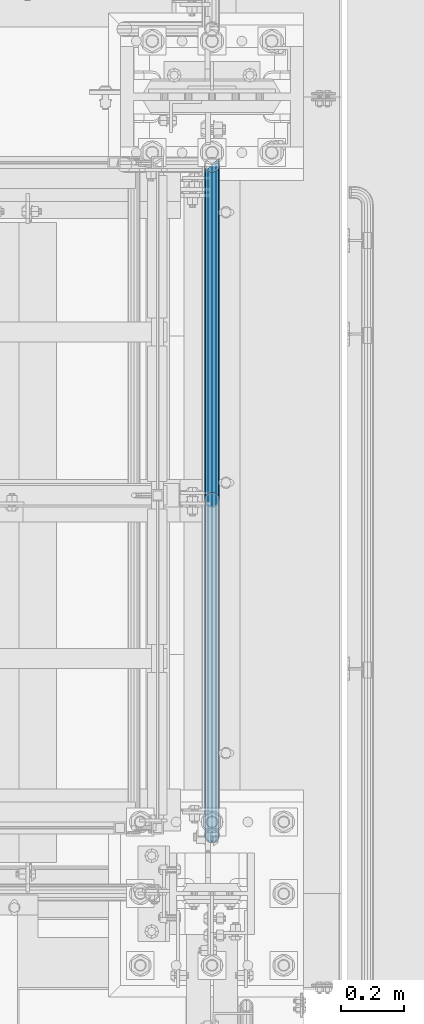
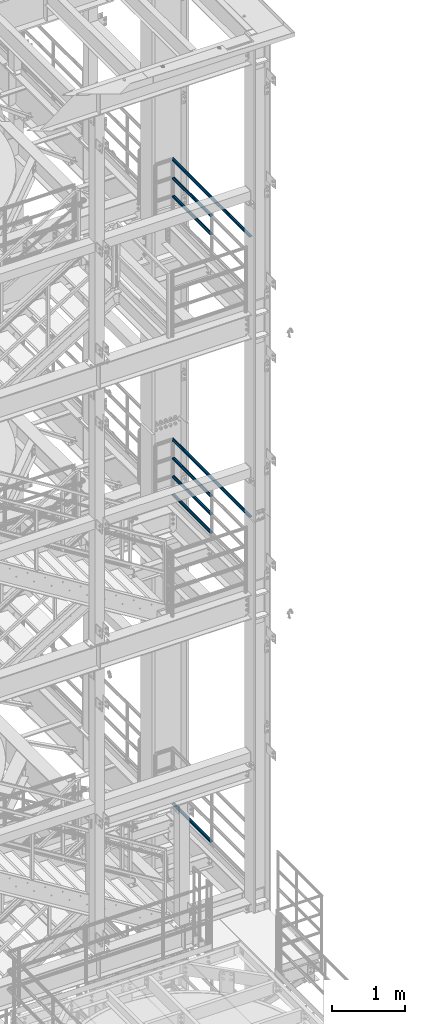
# One storey, part 1001 of 1876: 8 beams, 3 elements without a shape of their own.
"""IFC2X3 building model written with IfcOpenShell, lengths in millimetres."""

from ifc_helpers import new_model, si_unit, frame, origin_with_axes, place, context, subcontext, project, spatial, faceted_brep, material, type_object, element, aggregate, save


model = new_model("IFC2X3")

# Units and contexts
model_context = context("Model", 3, precision=1e-05, world=origin_with_axes())
body_context = subcontext(model_context, "Body", "Model", "MODEL_VIEW")
ifc_project = project(units=[si_unit("LENGTHUNIT", "METRE", prefix="MILLI"), si_unit("AREAUNIT", "SQUARE_METRE"), si_unit("VOLUMEUNIT", "CUBIC_METRE"), si_unit("MASSUNIT", "GRAM", prefix="KILO"), si_unit("TIMEUNIT", "SECOND"), si_unit("PLANEANGLEUNIT", "RADIAN"), si_unit("SOLIDANGLEUNIT", "STERADIAN"), si_unit("THERMODYNAMICTEMPERATUREUNIT", "DEGREE_CELSIUS"), si_unit("LUMINOUSINTENSITYUNIT", "LUMEN")], contexts=[model_context])

# Site, building, storey
site_placement = place(None, origin_with_axes())
site = spatial("IfcSite", under=ifc_project, at=site_placement, CompositionType="ELEMENT")
building_placement = place(site_placement, origin_with_axes())
building = spatial("IfcBuilding", under=site, at=building_placement, Name="Undefined", CompositionType="ELEMENT")
storey_placement = place(building_placement, origin_with_axes())
storey = spatial("IfcBuildingStorey", under=building, at=storey_placement, Name="Undefined", CompositionType="ELEMENT", Elevation=0.0)

# Assembly, beams
assembly_1_placement = place(storey_placement, origin_with_axes())
assembly_1 = element("IfcElementAssembly", 1, at=assembly_1_placement, inside=storey, Name="RAIL", AssemblyPlace="NOTDEFINED", PredefinedType="RIGID_FRAME")
ifc_material = material()
beam_type = type_object("IfcBeamType", Name="PIPE1-1/2SCH40", PredefinedType="NOTDEFINED")
beam_1_placement = place(assembly_1_placement, frame((7620.00000000001, -5857.08125, 18449.925), z_axis=(0.0, 0.0, -1.0), x_axis=(0.0, 1.0, 0.0)))
beam_1 = element("IfcBeam", 2, at=beam_1_placement, type_object=beam_type, material=ifc_material, Name="RAIL", ObjectType="PIPE1-1/2SCH40", context=body_context, shape_type="Brep", body=[
    faceted_brep([(0.0, 24.1299999999992, 0.0), (12.0650000000064, 20.8971929933177, -12.0649999999987), (12.0650000000064, 20.8971929933177, 12.0649999999987), (12.0650000000064, -20.8971929933177, 12.0649999999987), (12.0650000000064, -20.8971929933177, -12.0649999999987), (0.0, -24.1299999999992, 0.0), (20.8971929933249, -12.0650000000005, 20.8971929933177), (20.8971929933249, -12.0650000000005, 15.8661214311796), (15.2545715621445, -17.7076214311801, 10.2235000000001), (12.5151929933249, -20.4470000000001, 0.0), (15.2545715621445, -17.7076214311801, -10.2235000000001), (20.8971929933249, -12.0650000000005, -15.8661214311796), (20.8971929933249, -12.0650000000005, -20.8971929933177), (24.1300000000063, 0.0, -20.4470000000001), (24.1300000000063, 0.0, -24.130000000001), (21.3906214311868, -10.2235000000001, -17.7076214311819), (21.3906214311868, 10.2235000000001, -17.7076214311819), (20.8971929933249, 12.0650000000005, -15.8661214311796), (20.8971929933249, 12.0650000000005, -20.8971929933177), (15.2545715621445, 17.7076214311801, -10.2235000000001), (12.5151929933249, 20.4470000000001, 0.0), (15.2545715621445, 17.7076214311801, 10.2235000000001), (20.8971929933249, 12.0650000000005, 15.8661214311796), (20.8971929933249, 12.0650000000005, 20.8971929933177), (21.3906214311868, 10.2235000000001, 17.7076214311819), (24.1300000000064, 0.0, 20.4470000000001), (24.1300000000064, 0.0, 24.130000000001), (21.3906214311868, -10.2235000000001, 17.7076214311819), (1068.86375, 24.1300000000001, 0.0), (1056.79875, 20.8971929933186, -12.0649999999987), (1047.96655700668, 12.0649999999996, -20.8971929933177), (1068.86375, -24.1299999999792, 0.0), (1056.79875, -20.8971929933186, -12.0649999999987), (1056.79875, -20.8971929933186, 12.0649999999987), (1047.96655700668, -12.0649999999996, 20.8971929933177), (1047.96655700668, -12.0649999999996, -20.8971929933177), (1044.73375, 0.0, -24.130000000001), (1047.47312856881, 10.2235000000001, -17.7076214311819), (1044.73375, 0.0, -20.4470000000001), (1047.96655700668, 12.0650000000205, -15.8661214311578), (1047.96655700668, -12.0649999999787, -15.8661214312015), (1047.47312856882, -10.2235000000001, -17.7076214311819), (1053.60917843788, -17.7076214311801, -10.2235000000001), (1056.3485570067, -20.4470000000001, 0.0), (1053.60917843788, -17.7076214311801, 10.2235000000001), (1047.96655700668, -12.0649999999787, 15.8661214312015), (1047.47312856882, -10.2235000000001, 17.7076214311819), (1044.73375, 9.09494701772928e-13, 20.4470000000001), (1044.73375, 9.09494701772928e-13, 24.130000000001), (1047.96655700668, 12.0649999999996, 20.8971929933177), (1056.79875, 20.8971929933186, 12.0649999999987), (1047.96655700668, 12.0650000000205, 15.8661214311578), (1053.60917843784, 17.7076214311801, 10.2235000000001), (1056.34855700666, 20.4470000000001, 0.0), (1053.60917843784, 17.7076214311801, -10.2235000000001), (1047.47312856881, 10.2235000000001, 17.7076214311819)], [[[0, 1, 2]], [[3, 4, 5]], [[6, 7, 8, 9, 10, 11, 12, 4, 3]], [[13, 14, 12, 11, 15]], [[16, 17, 18, 14, 13]], [[2, 1, 18, 17, 19, 20, 21, 22, 23]], [[23, 22, 24, 25, 26]], [[26, 25, 27, 7, 6]], [[1, 0, 28, 29]], [[18, 1, 29, 30]], [[31, 32, 33]], [[6, 3, 33, 34]], [[3, 5, 31, 33]], [[5, 4, 32, 31]], [[4, 12, 35, 32]], [[12, 14, 36, 35]], [[14, 18, 30, 36]], [[37, 38, 36, 30, 39]], [[40, 35, 36, 38, 41]], [[33, 32, 35, 40, 42, 43, 44, 45, 34]], [[34, 45, 46, 47, 48]], [[26, 6, 34, 48]], [[2, 23, 49, 50]], [[23, 26, 48, 49]], [[0, 2, 50, 28]], [[28, 50, 29]], [[49, 51, 52, 53, 54, 39, 30, 29, 50]], [[48, 47, 55, 51, 49]], [[25, 24, 55, 47]], [[55, 24, 22, 21, 52, 51]], [[21, 20, 53, 52]], [[20, 19, 54, 53]], [[19, 17, 16, 37, 39, 54]], [[16, 13, 38, 37]], [[13, 15, 41, 38]], [[41, 15, 11, 10, 42, 40]], [[10, 9, 43, 42]], [[9, 8, 44, 43]], [[8, 7, 27, 46, 45, 44]], [[27, 25, 47, 46]]]),
])
beam_2_placement = place(assembly_1_placement, frame((7620.00000000001, -5857.08125, 18754.725), z_axis=(0.0, 0.0, -1.0), x_axis=(0.0, 1.0, 0.0)))
beam_2 = element("IfcBeam", 3, at=beam_2_placement, type_object=beam_type, material=ifc_material, Name="RAIL", ObjectType="PIPE1-1/2SCH40", context=body_context, shape_type="Brep", body=[
    faceted_brep([(0.0, 24.1299999999992, 0.0), (12.0650000000064, 20.8971929933177, -12.0649999999987), (12.0650000000064, 20.8971929933177, 12.0649999999987), (12.0650000000064, -20.8971929933177, 12.0649999999987), (12.0650000000064, -20.8971929933177, -12.0649999999987), (0.0, -24.1299999999992, 0.0), (20.8971929933249, -12.0650000000005, 20.8971929933177), (20.8971929933249, -12.0650000000005, 15.8661214311796), (15.2545715621445, -17.7076214311801, 10.2235000000001), (12.5151929933249, -20.4470000000001, 0.0), (15.2545715621445, -17.7076214311801, -10.2235000000001), (20.8971929933249, -12.0650000000005, -15.8661214311796), (20.8971929933249, -12.0650000000005, -20.8971929933177), (24.1300000000063, 0.0, -20.4470000000001), (24.1300000000063, 0.0, -24.130000000001), (21.3906214311868, -10.2235000000001, -17.7076214311819), (21.3906214311868, 10.2235000000001, -17.7076214311819), (20.8971929933249, 12.0650000000005, -15.8661214311796), (20.8971929933249, 12.0650000000005, -20.8971929933177), (15.2545715621445, 17.7076214311801, -10.2235000000001), (12.5151929933249, 20.4470000000001, 0.0), (15.2545715621445, 17.7076214311801, 10.2235000000001), (20.8971929933249, 12.0650000000005, 15.8661214311796), (20.8971929933249, 12.0650000000005, 20.8971929933177), (21.3906214311868, 10.2235000000001, 17.7076214311819), (24.1300000000064, 0.0, 20.4470000000001), (24.1300000000064, 0.0, 24.130000000001), (21.3906214311868, -10.2235000000001, 17.7076214311819), (1068.86375, 24.1300000000001, 0.0), (1056.79875, 20.8971929933186, -12.0649999999987), (1047.96655700668, 12.0649999999996, -20.8971929933177), (1068.86375, -24.1299999999792, 0.0), (1056.79875, -20.8971929933186, -12.0649999999987), (1056.79875, -20.8971929933186, 12.0649999999987), (1047.96655700668, -12.0649999999996, 20.8971929933177), (1047.96655700668, -12.0649999999996, -20.8971929933177), (1044.73375, 0.0, -24.130000000001), (1047.47312856881, 10.2235000000001, -17.7076214311819), (1044.73375, 0.0, -20.4470000000001), (1047.96655700668, 12.0650000000205, -15.8661214311578), (1047.96655700668, -12.0649999999787, -15.8661214312015), (1047.47312856882, -10.2235000000001, -17.7076214311819), (1053.60917843788, -17.7076214311801, -10.2235000000001), (1056.3485570067, -20.4470000000001, 0.0), (1053.60917843788, -17.7076214311801, 10.2235000000001), (1047.96655700668, -12.0649999999787, 15.8661214312015), (1047.47312856882, -10.2235000000001, 17.7076214311819), (1044.73375, 9.09494701772928e-13, 20.4470000000001), (1044.73375, 9.09494701772928e-13, 24.130000000001), (1047.96655700668, 12.0649999999996, 20.8971929933177), (1056.79875, 20.8971929933186, 12.0649999999987), (1047.96655700668, 12.0650000000205, 15.8661214311578), (1053.60917843784, 17.7076214311801, 10.2235000000001), (1056.34855700666, 20.4470000000001, 0.0), (1053.60917843784, 17.7076214311801, -10.2235000000001), (1047.47312856881, 10.2235000000001, 17.7076214311819)], [[[0, 1, 2]], [[3, 4, 5]], [[6, 7, 8, 9, 10, 11, 12, 4, 3]], [[13, 14, 12, 11, 15]], [[16, 17, 18, 14, 13]], [[2, 1, 18, 17, 19, 20, 21, 22, 23]], [[23, 22, 24, 25, 26]], [[26, 25, 27, 7, 6]], [[1, 0, 28, 29]], [[18, 1, 29, 30]], [[31, 32, 33]], [[6, 3, 33, 34]], [[3, 5, 31, 33]], [[5, 4, 32, 31]], [[4, 12, 35, 32]], [[12, 14, 36, 35]], [[14, 18, 30, 36]], [[37, 38, 36, 30, 39]], [[40, 35, 36, 38, 41]], [[33, 32, 35, 40, 42, 43, 44, 45, 34]], [[34, 45, 46, 47, 48]], [[26, 6, 34, 48]], [[2, 23, 49, 50]], [[23, 26, 48, 49]], [[0, 2, 50, 28]], [[28, 50, 29]], [[49, 51, 52, 53, 54, 39, 30, 29, 50]], [[48, 47, 55, 51, 49]], [[25, 24, 55, 47]], [[55, 24, 22, 21, 52, 51]], [[21, 20, 53, 52]], [[20, 19, 54, 53]], [[19, 17, 16, 37, 39, 54]], [[16, 13, 38, 37]], [[13, 15, 41, 38]], [[41, 15, 11, 10, 42, 40]], [[10, 9, 43, 42]], [[9, 8, 44, 43]], [[8, 7, 27, 46, 45, 44]], [[27, 25, 47, 46]]]),
])
beam_3_placement = place(assembly_1_placement, frame((7620.00000000001, -6950.075, 19059.525), z_axis=(0.0, 0.0, -1.0), x_axis=(0.0, 1.0, 0.0)))
beam_3 = element("IfcBeam", 4, at=beam_3_placement, type_object=beam_type, material=ifc_material, Name="RAIL", ObjectType="PIPE1-1/2SCH40", context=body_context, shape_type="Brep", body=[
    faceted_brep([(24.1300000000001, -20.4469999999999, 0.0), (34.3535000000002, -17.7076214311803, 10.2235000000001), (2144.14987856882, -17.7076214311801, 10.2235000000001), (2141.4105, -20.4470000000001, 0.0), (41.8376214311802, -10.2235000000001, 17.7076214311819), (2151.634, -10.2235000000001, 17.7076214311819), (44.5770000000002, 0.0, 20.4470000000001), (2161.8575, 0.0, 20.4470000000001), (41.8376214311802, 10.2235000000001, 17.7076214311819), (2172.081, 10.2235000000001, 17.7076214311819), (34.3535000000002, 17.7076214311803, 10.2235000000001), (2179.56512143118, 17.7076214311801, 10.2235000000001), (24.1300000000001, 20.4469999999999, 0.0), (2182.3045, 20.4470000000001, 0.0), (13.9065000000001, 17.7076214311803, -10.2235000000001), (2179.56512143118, 17.7076214311801, -10.2235000000001), (6.42237856882002, 10.2235000000001, -17.7076214311819), (2172.081, 10.2235000000001, -17.7076214311819), (3.68299999999999, 0.0, -20.4470000000001), (2161.8575, 0.0, -20.4470000000001), (6.42237856882002, -10.2235000000001, -17.7076214311819), (2151.634, -10.2235000000001, -17.7076214311819), (13.9065000000001, -17.7076214311803, -10.2235000000001), (2144.14987856882, -17.7076214311801, -10.2235000000001), (24.1299999999854, -24.1299999999992, 0.0), (12.0650000000064, -20.8971929933177, -12.0649999999987), (2140.96030700668, -20.8971929933186, -12.0649999999987), (2137.7275, -24.1300000000001, 0.0), (3.23280700668147, -12.0650000000001, -20.8971929933177), (2149.7925, -12.0649999999996, -20.8971929933177), (-1.45519152283669e-11, 0.0, -24.130000000001), (2161.8575, 0.0, -24.130000000001), (3.23280700668147, 12.0650000000001, -20.8971929933177), (2173.9225, 12.0649999999996, -20.8971929933177), (12.0650000000064, 20.8971929933177, -12.0649999999987), (2182.75469299332, 20.8971929933186, -12.0649999999987), (24.1300000000047, 24.1299999999992, 0.0), (2185.9875, 24.1300000000001, 0.0), (36.1949999999997, 20.8971929933184, 12.0649999999987), (2182.75469299332, 20.8971929933186, 12.0649999999987), (45.0271929933187, 12.0650000000001, 20.8971929933177), (2173.9225, 12.0649999999996, 20.8971929933177), (48.2600000000002, 0.0, 24.130000000001), (2161.8575, 0.0, 24.130000000001), (45.0271929933187, -12.0650000000001, 20.8971929933177), (2149.7925, -12.0649999999996, 20.8971929933177), (36.1949999999997, -20.8971929933184, 12.0649999999987), (2140.96030700668, -20.8971929933186, 12.0649999999987)], [[[0, 1, 2, 3]], [[1, 4, 5, 2]], [[4, 6, 7, 5]], [[6, 8, 9, 7]], [[8, 10, 11, 9]], [[10, 12, 13, 11]], [[12, 14, 15, 13]], [[14, 16, 17, 15]], [[16, 18, 19, 17]], [[18, 20, 21, 19]], [[20, 22, 23, 21]], [[22, 0, 3, 23]], [[24, 25, 26, 27]], [[25, 28, 29, 26]], [[28, 30, 31, 29]], [[30, 32, 33, 31]], [[32, 34, 35, 33]], [[34, 36, 37, 35]], [[36, 38, 39, 37]], [[38, 40, 41, 39]], [[40, 42, 43, 41]], [[42, 44, 45, 43]], [[44, 46, 47, 45]], [[46, 24, 27, 47]], [[29, 31, 33, 35, 37, 39, 41, 43, 45, 47, 27, 26], [5, 7, 9, 11, 13, 15, 17, 19, 21, 23, 3, 2]], [[46, 44, 42, 40, 38, 36, 34, 32, 30, 28, 25, 24], [22, 20, 18, 16, 14, 12, 10, 8, 6, 4, 1, 0]]]),
])
aggregate(assembly_1, [beam_1, beam_2, beam_3])

assembly_2_placement = place(storey_placement, origin_with_axes())
assembly_2 = element("IfcElementAssembly", 5, at=assembly_2_placement, inside=storey, Name="RAIL", AssemblyPlace="NOTDEFINED", PredefinedType="RIGID_FRAME")
beam_4_placement = place(assembly_2_placement, frame((7619.99999999997, -4788.2175, 13471.525), z_axis=(0.0, 0.0, 1.0), x_axis=(0.0, -1.0, 0.0)))
beam_4 = element("IfcBeam", 6, at=beam_4_placement, type_object=beam_type, material=ifc_material, Name="RAIL", ObjectType="PIPE1-1/2SCH40", context=body_context, shape_type="Brep", body=[
    faceted_brep([(1047.96655700668, -12.0649999999996, 20.8971929933177), (1047.96655700668, -12.0649999999787, 15.8661214312015), (1047.47312856882, -10.2235000000001, 17.7076214311819), (1044.73375, 9.09494701772928e-13, 20.4470000000001), (1044.73375, 9.09494701772928e-13, 24.130000000001), (1047.47312856881, 10.2235000000001, 17.7076214311819), (1047.96655700668, 12.0650000000205, 15.8661214311578), (1047.96655700668, 12.0649999999996, 20.8971929933177), (1068.86375, 24.1300000000001, 0.0), (1056.79875, 20.8971929933186, 12.0649999999987), (1056.79875, 20.8971929933186, -12.0649999999987), (1053.60917843784, 17.7076214311801, 10.2235000000001), (1056.34855700666, 20.4470000000001, 0.0), (1053.60917843784, 17.7076214311801, -10.2235000000001), (1047.96655700668, 12.0650000000205, -15.8661214311578), (1047.96655700668, 12.0649999999996, -20.8971929933177), (1047.47312856881, 10.2235000000001, -17.7076214311819), (1044.73375, 0.0, -20.4470000000001), (1044.73375, 0.0, -24.130000000001), (1047.96655700668, -12.0649999999787, -15.8661214312015), (1047.96655700668, -12.0649999999996, -20.8971929933177), (1047.47312856882, -10.2235000000001, -17.7076214311819), (1068.86375, -24.1299999999792, 0.0), (1056.79875, -20.8971929933186, -12.0649999999987), (1056.79875, -20.8971929933186, 12.0649999999987), (1053.60917843788, -17.7076214311801, -10.2235000000001), (1056.3485570067, -20.4470000000001, 0.0), (1053.60917843788, -17.7076214311801, 10.2235000000001), (12.0650000000064, -20.8971929933177, -12.0649999999987), (20.8971929933249, -12.0650000000005, -20.8971929933177), (0.0, 24.1299999999992, 0.0), (12.0650000000064, 20.8971929933177, -12.0649999999987), (12.0650000000064, 20.8971929933177, 12.0649999999987), (20.8971929933249, 12.0650000000005, 20.8971929933177), (24.1300000000064, 0.0, 24.130000000001), (20.8971929933249, 12.0650000000005, -20.8971929933177), (24.1300000000063, 0.0, -24.130000000001), (24.1300000000063, 0.0, -20.4470000000001), (20.8971929933249, -12.0650000000005, -15.8661214311796), (21.3906214311868, -10.2235000000001, -17.7076214311819), (21.3906214311868, 10.2235000000001, -17.7076214311819), (20.8971929933249, 12.0650000000005, -15.8661214311796), (15.2545715621445, 17.7076214311801, -10.2235000000001), (12.5151929933249, 20.4470000000001, 0.0), (15.2545715621445, 17.7076214311801, 10.2235000000001), (20.8971929933249, 12.0650000000005, 15.8661214311796), (21.3906214311868, 10.2235000000001, 17.7076214311819), (24.1300000000064, 0.0, 20.4470000000001), (21.3906214311868, -10.2235000000001, 17.7076214311819), (20.8971929933249, -12.0650000000005, 15.8661214311796), (20.8971929933249, -12.0650000000005, 20.8971929933177), (12.0650000000064, -20.8971929933177, 12.0649999999987), (0.0, -24.1299999999992, 0.0), (15.2545715621445, -17.7076214311801, 10.2235000000001), (12.5151929933249, -20.4470000000001, 0.0), (15.2545715621445, -17.7076214311801, -10.2235000000001)], [[[0, 1, 2, 3, 4]], [[4, 3, 5, 6, 7]], [[8, 9, 10]], [[7, 6, 11, 12, 13, 14, 15, 10, 9]], [[16, 17, 18, 15, 14]], [[19, 20, 18, 17, 21]], [[22, 23, 24]], [[24, 23, 20, 19, 25, 26, 27, 1, 0]], [[28, 29, 20, 23]], [[30, 31, 32]], [[33, 34, 4, 7]], [[32, 33, 7, 9]], [[30, 32, 9, 8]], [[31, 30, 8, 10]], [[35, 31, 10, 15]], [[36, 35, 15, 18]], [[29, 36, 18, 20]], [[37, 36, 29, 38, 39]], [[40, 41, 35, 36, 37]], [[32, 31, 35, 41, 42, 43, 44, 45, 33]], [[33, 45, 46, 47, 34]], [[34, 47, 48, 49, 50]], [[34, 50, 0, 4]], [[50, 51, 24, 0]], [[51, 52, 22, 24]], [[52, 28, 23, 22]], [[51, 28, 52]], [[50, 49, 53, 54, 55, 38, 29, 28, 51]], [[55, 54, 26, 25]], [[21, 39, 38, 55, 25, 19]], [[37, 39, 21, 17]], [[40, 37, 17, 16]], [[42, 41, 40, 16, 14, 13]], [[43, 42, 13, 12]], [[44, 43, 12, 11]], [[5, 46, 45, 44, 11, 6]], [[47, 46, 5, 3]], [[48, 47, 3, 2]], [[53, 49, 48, 2, 1, 27]], [[54, 53, 27, 26]]]),
])
beam_5_placement = place(assembly_2_placement, frame((7620.00000000001, -5857.08125, 13776.325), z_axis=(0.0, 0.0, -1.0), x_axis=(0.0, 1.0, 0.0)))
beam_5 = element("IfcBeam", 7, at=beam_5_placement, type_object=beam_type, material=ifc_material, Name="RAIL", ObjectType="PIPE1-1/2SCH40", context=body_context, shape_type="Brep", body=[
    faceted_brep([(0.0, 24.1299999999992, 0.0), (12.0650000000064, 20.8971929933177, -12.0649999999987), (12.0650000000064, 20.8971929933177, 12.0649999999987), (12.0650000000064, -20.8971929933177, 12.0649999999987), (12.0650000000064, -20.8971929933177, -12.0649999999987), (0.0, -24.1299999999992, 0.0), (20.8971929933249, -12.0650000000005, 20.8971929933177), (20.8971929933249, -12.0650000000005, 15.8661214311796), (15.2545715621445, -17.7076214311801, 10.2235000000001), (12.5151929933249, -20.4470000000001, 0.0), (15.2545715621445, -17.7076214311801, -10.2235000000001), (20.8971929933249, -12.0650000000005, -15.8661214311796), (20.8971929933249, -12.0650000000005, -20.8971929933177), (24.1300000000063, 0.0, -20.4470000000001), (24.1300000000063, 0.0, -24.130000000001), (21.3906214311868, -10.2235000000001, -17.7076214311819), (21.3906214311868, 10.2235000000001, -17.7076214311819), (20.8971929933249, 12.0650000000005, -15.8661214311796), (20.8971929933249, 12.0650000000005, -20.8971929933177), (15.2545715621445, 17.7076214311801, -10.2235000000001), (12.5151929933249, 20.4470000000001, 0.0), (15.2545715621445, 17.7076214311801, 10.2235000000001), (20.8971929933249, 12.0650000000005, 15.8661214311796), (20.8971929933249, 12.0650000000005, 20.8971929933177), (21.3906214311868, 10.2235000000001, 17.7076214311819), (24.1300000000064, 0.0, 20.4470000000001), (24.1300000000064, 0.0, 24.130000000001), (21.3906214311868, -10.2235000000001, 17.7076214311819), (1068.86375, 24.1300000000001, 0.0), (1056.79875, 20.8971929933186, -12.0649999999987), (1047.96655700668, 12.0649999999996, -20.8971929933177), (1068.86375, -24.1299999999792, 0.0), (1056.79875, -20.8971929933186, -12.0649999999987), (1056.79875, -20.8971929933186, 12.0649999999987), (1047.96655700668, -12.0649999999996, 20.8971929933177), (1047.96655700668, -12.0649999999996, -20.8971929933177), (1044.73375, 0.0, -24.130000000001), (1047.47312856881, 10.2235000000001, -17.7076214311819), (1044.73375, 0.0, -20.4470000000001), (1047.96655700668, 12.0650000000205, -15.8661214311578), (1047.96655700668, -12.0649999999787, -15.8661214312015), (1047.47312856882, -10.2235000000001, -17.7076214311819), (1053.60917843788, -17.7076214311801, -10.2235000000001), (1056.3485570067, -20.4470000000001, 0.0), (1053.60917843788, -17.7076214311801, 10.2235000000001), (1047.96655700668, -12.0649999999787, 15.8661214312015), (1047.47312856882, -10.2235000000001, 17.7076214311819), (1044.73375, 9.09494701772928e-13, 20.4470000000001), (1044.73375, 9.09494701772928e-13, 24.130000000001), (1047.96655700668, 12.0649999999996, 20.8971929933177), (1056.79875, 20.8971929933186, 12.0649999999987), (1047.96655700668, 12.0650000000205, 15.8661214311578), (1053.60917843784, 17.7076214311801, 10.2235000000001), (1056.34855700666, 20.4470000000001, 0.0), (1053.60917843784, 17.7076214311801, -10.2235000000001), (1047.47312856881, 10.2235000000001, 17.7076214311819)], [[[0, 1, 2]], [[3, 4, 5]], [[6, 7, 8, 9, 10, 11, 12, 4, 3]], [[13, 14, 12, 11, 15]], [[16, 17, 18, 14, 13]], [[2, 1, 18, 17, 19, 20, 21, 22, 23]], [[23, 22, 24, 25, 26]], [[26, 25, 27, 7, 6]], [[1, 0, 28, 29]], [[18, 1, 29, 30]], [[31, 32, 33]], [[6, 3, 33, 34]], [[3, 5, 31, 33]], [[5, 4, 32, 31]], [[4, 12, 35, 32]], [[12, 14, 36, 35]], [[14, 18, 30, 36]], [[37, 38, 36, 30, 39]], [[40, 35, 36, 38, 41]], [[33, 32, 35, 40, 42, 43, 44, 45, 34]], [[34, 45, 46, 47, 48]], [[26, 6, 34, 48]], [[2, 23, 49, 50]], [[23, 26, 48, 49]], [[0, 2, 50, 28]], [[28, 50, 29]], [[49, 51, 52, 53, 54, 39, 30, 29, 50]], [[48, 47, 55, 51, 49]], [[25, 24, 55, 47]], [[55, 24, 22, 21, 52, 51]], [[21, 20, 53, 52]], [[20, 19, 54, 53]], [[19, 17, 16, 37, 39, 54]], [[16, 13, 38, 37]], [[13, 15, 41, 38]], [[41, 15, 11, 10, 42, 40]], [[10, 9, 43, 42]], [[9, 8, 44, 43]], [[8, 7, 27, 46, 45, 44]], [[27, 25, 47, 46]]]),
])
beam_6_placement = place(assembly_2_placement, frame((7620.00000000001, -5857.08125, 14081.125), z_axis=(0.0, 0.0, -1.0), x_axis=(0.0, 1.0, 0.0)))
beam_6 = element("IfcBeam", 8, at=beam_6_placement, type_object=beam_type, material=ifc_material, Name="RAIL", ObjectType="PIPE1-1/2SCH40", context=body_context, shape_type="Brep", body=[
    faceted_brep([(0.0, 24.1299999999992, 0.0), (12.0650000000064, 20.8971929933177, -12.0649999999987), (12.0650000000064, 20.8971929933177, 12.0649999999987), (12.0650000000064, -20.8971929933177, 12.0649999999987), (12.0650000000064, -20.8971929933177, -12.0649999999987), (0.0, -24.1299999999992, 0.0), (20.8971929933249, -12.0650000000005, 20.8971929933177), (20.8971929933249, -12.0650000000005, 15.8661214311796), (15.2545715621445, -17.7076214311801, 10.2235000000001), (12.5151929933249, -20.4470000000001, 0.0), (15.2545715621445, -17.7076214311801, -10.2235000000001), (20.8971929933249, -12.0650000000005, -15.8661214311796), (20.8971929933249, -12.0650000000005, -20.8971929933177), (24.1300000000063, 0.0, -20.4470000000001), (24.1300000000063, 0.0, -24.130000000001), (21.3906214311868, -10.2235000000001, -17.7076214311819), (21.3906214311868, 10.2235000000001, -17.7076214311819), (20.8971929933249, 12.0650000000005, -15.8661214311796), (20.8971929933249, 12.0650000000005, -20.8971929933177), (15.2545715621445, 17.7076214311801, -10.2235000000001), (12.5151929933249, 20.4470000000001, 0.0), (15.2545715621445, 17.7076214311801, 10.2235000000001), (20.8971929933249, 12.0650000000005, 15.8661214311796), (20.8971929933249, 12.0650000000005, 20.8971929933177), (21.3906214311868, 10.2235000000001, 17.7076214311819), (24.1300000000064, 0.0, 20.4470000000001), (24.1300000000064, 0.0, 24.130000000001), (21.3906214311868, -10.2235000000001, 17.7076214311819), (1068.86375, 24.1300000000001, 0.0), (1056.79875, 20.8971929933186, -12.0649999999987), (1047.96655700668, 12.0649999999996, -20.8971929933177), (1068.86375, -24.1299999999792, 0.0), (1056.79875, -20.8971929933186, -12.0649999999987), (1056.79875, -20.8971929933186, 12.0649999999987), (1047.96655700668, -12.0649999999996, 20.8971929933177), (1047.96655700668, -12.0649999999996, -20.8971929933177), (1044.73375, 0.0, -24.130000000001), (1047.47312856881, 10.2235000000001, -17.7076214311819), (1044.73375, 0.0, -20.4470000000001), (1047.96655700668, 12.0650000000205, -15.8661214311578), (1047.96655700668, -12.0649999999787, -15.8661214312015), (1047.47312856882, -10.2235000000001, -17.7076214311819), (1053.60917843788, -17.7076214311801, -10.2235000000001), (1056.3485570067, -20.4470000000001, 0.0), (1053.60917843788, -17.7076214311801, 10.2235000000001), (1047.96655700668, -12.0649999999787, 15.8661214312015), (1047.47312856882, -10.2235000000001, 17.7076214311819), (1044.73375, 9.09494701772928e-13, 20.4470000000001), (1044.73375, 9.09494701772928e-13, 24.130000000001), (1047.96655700668, 12.0649999999996, 20.8971929933177), (1056.79875, 20.8971929933186, 12.0649999999987), (1047.96655700668, 12.0650000000205, 15.8661214311578), (1053.60917843784, 17.7076214311801, 10.2235000000001), (1056.34855700666, 20.4470000000001, 0.0), (1053.60917843784, 17.7076214311801, -10.2235000000001), (1047.47312856881, 10.2235000000001, 17.7076214311819)], [[[0, 1, 2]], [[3, 4, 5]], [[6, 7, 8, 9, 10, 11, 12, 4, 3]], [[13, 14, 12, 11, 15]], [[16, 17, 18, 14, 13]], [[2, 1, 18, 17, 19, 20, 21, 22, 23]], [[23, 22, 24, 25, 26]], [[26, 25, 27, 7, 6]], [[1, 0, 28, 29]], [[18, 1, 29, 30]], [[31, 32, 33]], [[6, 3, 33, 34]], [[3, 5, 31, 33]], [[5, 4, 32, 31]], [[4, 12, 35, 32]], [[12, 14, 36, 35]], [[14, 18, 30, 36]], [[37, 38, 36, 30, 39]], [[40, 35, 36, 38, 41]], [[33, 32, 35, 40, 42, 43, 44, 45, 34]], [[34, 45, 46, 47, 48]], [[26, 6, 34, 48]], [[2, 23, 49, 50]], [[23, 26, 48, 49]], [[0, 2, 50, 28]], [[28, 50, 29]], [[49, 51, 52, 53, 54, 39, 30, 29, 50]], [[48, 47, 55, 51, 49]], [[25, 24, 55, 47]], [[55, 24, 22, 21, 52, 51]], [[21, 20, 53, 52]], [[20, 19, 54, 53]], [[19, 17, 16, 37, 39, 54]], [[16, 13, 38, 37]], [[13, 15, 41, 38]], [[41, 15, 11, 10, 42, 40]], [[10, 9, 43, 42]], [[9, 8, 44, 43]], [[8, 7, 27, 46, 45, 44]], [[27, 25, 47, 46]]]),
])
beam_7_placement = place(assembly_2_placement, frame((7620.00000000001, -6950.075, 14385.925), z_axis=(0.0, 0.0, -1.0), x_axis=(0.0, 1.0, 0.0)))
beam_7 = element("IfcBeam", 9, at=beam_7_placement, type_object=beam_type, material=ifc_material, Name="RAIL", ObjectType="PIPE1-1/2SCH40", context=body_context, shape_type="Brep", body=[
    faceted_brep([(24.1300000000001, -20.4469999999999, 0.0), (34.3535000000002, -17.7076214311803, 10.2235000000001), (2144.14987856882, -17.7076214311801, 10.2235000000001), (2141.4105, -20.4470000000001, 0.0), (41.8376214311802, -10.2235000000001, 17.7076214311819), (2151.634, -10.2235000000001, 17.7076214311819), (44.5770000000002, 0.0, 20.4470000000001), (2161.8575, 0.0, 20.4470000000001), (41.8376214311802, 10.2235000000001, 17.7076214311819), (2172.081, 10.2235000000001, 17.7076214311819), (34.3535000000002, 17.7076214311803, 10.2235000000001), (2179.56512143118, 17.7076214311801, 10.2235000000001), (24.1300000000001, 20.4469999999999, 0.0), (2182.3045, 20.4470000000001, 0.0), (13.9065000000001, 17.7076214311803, -10.2235000000001), (2179.56512143118, 17.7076214311801, -10.2235000000001), (6.42237856882002, 10.2235000000001, -17.7076214311819), (2172.081, 10.2235000000001, -17.7076214311819), (3.68299999999999, 0.0, -20.4470000000001), (2161.8575, 0.0, -20.4470000000001), (6.42237856882002, -10.2235000000001, -17.7076214311819), (2151.634, -10.2235000000001, -17.7076214311819), (13.9065000000001, -17.7076214311803, -10.2235000000001), (2144.14987856882, -17.7076214311801, -10.2235000000001), (24.1299999999854, -24.1299999999992, 0.0), (12.0650000000064, -20.8971929933177, -12.0649999999987), (2140.96030700668, -20.8971929933186, -12.0649999999987), (2137.7275, -24.1300000000001, 0.0), (3.23280700668147, -12.0650000000001, -20.8971929933177), (2149.7925, -12.0649999999996, -20.8971929933177), (-1.45519152283669e-11, 0.0, -24.130000000001), (2161.8575, 0.0, -24.130000000001), (3.23280700668147, 12.0650000000001, -20.8971929933177), (2173.9225, 12.0649999999996, -20.8971929933177), (12.0650000000064, 20.8971929933177, -12.0649999999987), (2182.75469299332, 20.8971929933186, -12.0649999999987), (24.1300000000047, 24.1299999999992, 0.0), (2185.9875, 24.1300000000001, 0.0), (36.1949999999997, 20.8971929933184, 12.0649999999987), (2182.75469299332, 20.8971929933186, 12.0649999999987), (45.0271929933187, 12.0650000000001, 20.8971929933177), (2173.9225, 12.0649999999996, 20.8971929933177), (48.2600000000002, 0.0, 24.130000000001), (2161.8575, 0.0, 24.130000000001), (45.0271929933187, -12.0650000000001, 20.8971929933177), (2149.7925, -12.0649999999996, 20.8971929933177), (36.1949999999997, -20.8971929933184, 12.0649999999987), (2140.96030700668, -20.8971929933186, 12.0649999999987)], [[[0, 1, 2, 3]], [[1, 4, 5, 2]], [[4, 6, 7, 5]], [[6, 8, 9, 7]], [[8, 10, 11, 9]], [[10, 12, 13, 11]], [[12, 14, 15, 13]], [[14, 16, 17, 15]], [[16, 18, 19, 17]], [[18, 20, 21, 19]], [[20, 22, 23, 21]], [[22, 0, 3, 23]], [[24, 25, 26, 27]], [[25, 28, 29, 26]], [[28, 30, 31, 29]], [[30, 32, 33, 31]], [[32, 34, 35, 33]], [[34, 36, 37, 35]], [[36, 38, 39, 37]], [[38, 40, 41, 39]], [[40, 42, 43, 41]], [[42, 44, 45, 43]], [[44, 46, 47, 45]], [[46, 24, 27, 47]], [[29, 31, 33, 35, 37, 39, 41, 43, 45, 47, 27, 26], [5, 7, 9, 11, 13, 15, 17, 19, 21, 23, 3, 2]], [[46, 44, 42, 40, 38, 36, 34, 32, 30, 28, 25, 24], [22, 20, 18, 16, 14, 12, 10, 8, 6, 4, 1, 0]]]),
])
aggregate(assembly_2, [beam_4, beam_5, beam_6, beam_7])

# Assembly, beam
assembly_3_placement = place(storey_placement, origin_with_axes())
assembly_3 = element("IfcElementAssembly", 10, at=assembly_3_placement, inside=storey, Name="RAIL", AssemblyPlace="NOTDEFINED", PredefinedType="RIGID_FRAME")
beam_8_placement = place(assembly_3_placement, frame((7619.99999999997, -4788.2175, 8315.325), z_axis=(0.0, 0.0, 1.0), x_axis=(0.0, -1.0, 0.0)))
beam_8 = element("IfcBeam", 11, at=beam_8_placement, type_object=beam_type, material=ifc_material, Name="RAIL", ObjectType="PIPE1-1/2SCH40", context=body_context, shape_type="Brep", body=[
    faceted_brep([(1047.96655700668, -12.0649999999996, 20.8971929933177), (1047.96655700668, -12.0649999999787, 15.8661214312015), (1047.47312856882, -10.2235000000001, 17.7076214311819), (1044.73375, 9.09494701772928e-13, 20.4470000000001), (1044.73375, 9.09494701772928e-13, 24.130000000001), (1047.47312856881, 10.2235000000001, 17.7076214311819), (1047.96655700668, 12.0650000000205, 15.8661214311578), (1047.96655700668, 12.0649999999996, 20.8971929933177), (1068.86375, 24.1300000000001, 0.0), (1056.79875, 20.8971929933186, 12.0649999999987), (1056.79875, 20.8971929933186, -12.0649999999987), (1053.60917843784, 17.7076214311801, 10.2235000000001), (1056.34855700666, 20.4470000000001, 0.0), (1053.60917843784, 17.7076214311801, -10.2235000000001), (1047.96655700668, 12.0650000000205, -15.8661214311578), (1047.96655700668, 12.0649999999996, -20.8971929933177), (1047.47312856881, 10.2235000000001, -17.7076214311819), (1044.73375, 0.0, -20.4470000000001), (1044.73375, 0.0, -24.130000000001), (1047.96655700668, -12.0649999999787, -15.8661214312015), (1047.96655700668, -12.0649999999996, -20.8971929933177), (1047.47312856882, -10.2235000000001, -17.7076214311819), (1068.86375, -24.1299999999792, 0.0), (1056.79875, -20.8971929933186, -12.0649999999987), (1056.79875, -20.8971929933186, 12.0649999999987), (1053.60917843788, -17.7076214311801, -10.2235000000001), (1056.3485570067, -20.4470000000001, 0.0), (1053.60917843788, -17.7076214311801, 10.2235000000001), (12.0650000000064, -20.8971929933177, -12.0649999999987), (20.8971929933249, -12.0650000000005, -20.8971929933177), (0.0, 24.1299999999992, 0.0), (12.0650000000064, 20.8971929933177, -12.0649999999987), (12.0650000000064, 20.8971929933177, 12.0649999999987), (20.8971929933249, 12.0650000000005, 20.8971929933177), (24.1300000000064, 0.0, 24.130000000001), (20.8971929933249, 12.0650000000005, -20.8971929933177), (24.1300000000063, 0.0, -24.130000000001), (24.1300000000063, 0.0, -20.4470000000001), (20.8971929933249, -12.0650000000005, -15.8661214311796), (21.3906214311868, -10.2235000000001, -17.7076214311819), (21.3906214311868, 10.2235000000001, -17.7076214311819), (20.8971929933249, 12.0650000000005, -15.8661214311796), (15.2545715621445, 17.7076214311801, -10.2235000000001), (12.5151929933249, 20.4470000000001, 0.0), (15.2545715621445, 17.7076214311801, 10.2235000000001), (20.8971929933249, 12.0650000000005, 15.8661214311796), (21.3906214311868, 10.2235000000001, 17.7076214311819), (24.1300000000064, 0.0, 20.4470000000001), (21.3906214311868, -10.2235000000001, 17.7076214311819), (20.8971929933249, -12.0650000000005, 15.8661214311796), (20.8971929933249, -12.0650000000005, 20.8971929933177), (12.0650000000064, -20.8971929933177, 12.0649999999987), (0.0, -24.1299999999992, 0.0), (15.2545715621445, -17.7076214311801, 10.2235000000001), (12.5151929933249, -20.4470000000001, 0.0), (15.2545715621445, -17.7076214311801, -10.2235000000001)], [[[0, 1, 2, 3, 4]], [[4, 3, 5, 6, 7]], [[8, 9, 10]], [[7, 6, 11, 12, 13, 14, 15, 10, 9]], [[16, 17, 18, 15, 14]], [[19, 20, 18, 17, 21]], [[22, 23, 24]], [[24, 23, 20, 19, 25, 26, 27, 1, 0]], [[28, 29, 20, 23]], [[30, 31, 32]], [[33, 34, 4, 7]], [[32, 33, 7, 9]], [[30, 32, 9, 8]], [[31, 30, 8, 10]], [[35, 31, 10, 15]], [[36, 35, 15, 18]], [[29, 36, 18, 20]], [[37, 36, 29, 38, 39]], [[40, 41, 35, 36, 37]], [[32, 31, 35, 41, 42, 43, 44, 45, 33]], [[33, 45, 46, 47, 34]], [[34, 47, 48, 49, 50]], [[34, 50, 0, 4]], [[50, 51, 24, 0]], [[51, 52, 22, 24]], [[52, 28, 23, 22]], [[51, 28, 52]], [[50, 49, 53, 54, 55, 38, 29, 28, 51]], [[55, 54, 26, 25]], [[21, 39, 38, 55, 25, 19]], [[37, 39, 21, 17]], [[40, 37, 17, 16]], [[42, 41, 40, 16, 14, 13]], [[43, 42, 13, 12]], [[44, 43, 12, 11]], [[5, 46, 45, 44, 11, 6]], [[47, 46, 5, 3]], [[48, 47, 3, 2]], [[53, 49, 48, 2, 1, 27]], [[54, 53, 27, 26]]]),
])
aggregate(assembly_3, [beam_8])

save(model, "model.ifc")
